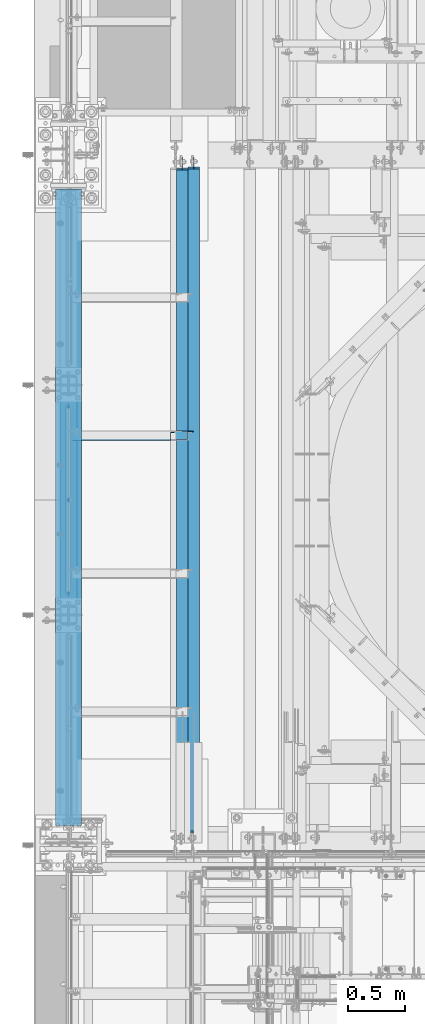
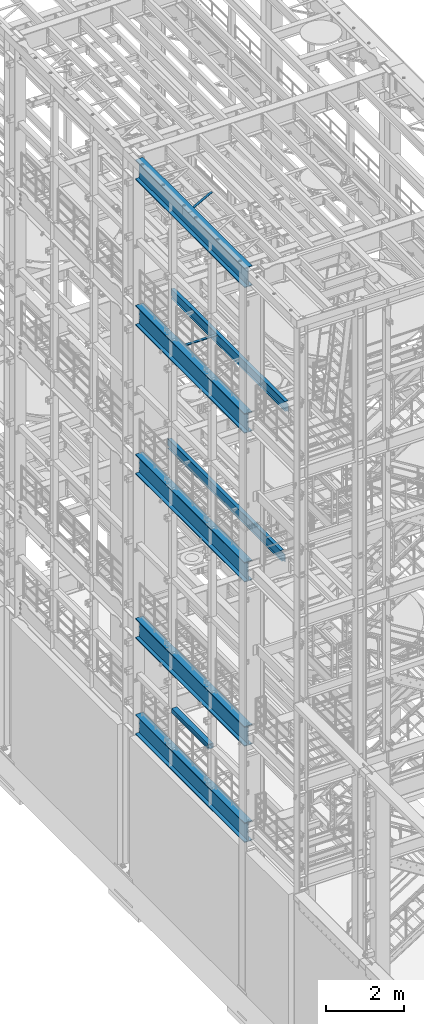
# One storey, part 1007 of 1876: 10 beams, 1 member, 11 elements without a shape of their own.
"""IFC2X3 building model written with IfcOpenShell, lengths in millimetres."""

import ifcopenshell
import ifcopenshell.guid

model = None  # the IFC model being written
_history = None  # IfcOwnerHistory: only IFC2X3 demands one
_inside = {}  # id of a spatial element -> (the spatial element, [elements in it])
_under = {}  # id of a project, library or spatial element -> (it, [spatial elements below it])
_declared = {}  # id of a project -> (the project, [libraries it declares])
_typed = {}  # id of a type object -> (the type object, [elements of that type])
_made_of = {}  # id of a material, layer set ... -> (it, [elements and type objects made of it])


def new_model(schema):
    """Start an empty IFC model of exactly this schema.

    Asked for "IFC4X3", IfcOpenShell would pick the latest addendum, in which some entities
    have other attributes; the version numbers below select the first issue.
    IFC2X3 requires an IfcOwnerHistory on every rooted entity: one is made here for all.
    """
    global model, _history
    if schema == "IFC4X3":
        model = ifcopenshell.file(schema_version=(4, 3, 0, 0))
    else:
        model = ifcopenshell.file(schema=schema)
    _inside.clear()
    _under.clear()
    _declared.clear()
    _typed.clear()
    _made_of.clear()
    _history = None
    if model.schema == "IFC2X3":
        org = make("IfcOrganization", Name="unknown")
        user = make(
            "IfcPersonAndOrganization",
            ThePerson=make("IfcPerson", FamilyName="unknown"),
            TheOrganization=org,
        )
        app = make(
            "IfcApplication",
            ApplicationDeveloper=org,
            Version="unknown",
            ApplicationFullName="unknown",
            ApplicationIdentifier="unknown",
        )
        _history = make(
            "IfcOwnerHistory",
            OwningUser=user,
            OwningApplication=app,
            ChangeAction="ADDED",
            CreationDate=0,
        )
    return model


def make(cls, **values):
    """One entity of the class cls with the attributes given. An attribute that is None is left unset."""
    return model.create_entity(
        cls, **{name: value for name, value in values.items() if value is not None}
    )


def rooted(cls, **values):
    """An entity with a GlobalId (a new one), such as an element, a storey or a relation."""
    return make(cls, GlobalId=ifcopenshell.guid.new(), OwnerHistory=_history, **values)


def si_unit(unit_type, name, prefix=None):
    """IfcSIUnit, for example si_unit("LENGTHUNIT", "METRE", prefix="MILLI")."""
    return make("IfcSIUnit", UnitType=unit_type, Prefix=prefix, Name=name)


def assignment(units):
    """IfcUnitAssignment: the units of a project."""
    return None if units is None else make("IfcUnitAssignment", Units=units)


def point(xyz):
    """IfcCartesianPoint."""
    return None if xyz is None else make("IfcCartesianPoint", Coordinates=xyz)


def direction(xyz):
    """IfcDirection."""
    return None if xyz is None else make("IfcDirection", DirectionRatios=xyz)


def frame(location, z_axis=None, x_axis=None):
    """IfcAxis2Placement3D, a coordinate frame: its origin and axes. An axis left out is left unset."""
    return make(
        "IfcAxis2Placement3D",
        Location=point(location),
        Axis=direction(z_axis),
        RefDirection=direction(x_axis),
    )


def origin_with_axes():
    """The frame at (0, 0, 0) with the z axis (0, 0, 1) and the x axis (1, 0, 0) written out."""
    return frame((0.0, 0.0, 0.0), z_axis=(0.0, 0.0, 1.0), x_axis=(1.0, 0.0, 0.0))


def place(relative_to, where):
    """IfcLocalPlacement: puts the frame where relative to a parent placement (None: the world)."""
    return make(
        "IfcLocalPlacement", PlacementRelTo=relative_to, RelativePlacement=where
    )


def context(
    kind, dimensions, precision=None, world=None, true_north=None, identifier=None
):
    """IfcGeometricRepresentationContext, for example the 3D "Model" context."""
    return make(
        "IfcGeometricRepresentationContext",
        ContextIdentifier=identifier,
        ContextType=kind,
        CoordinateSpaceDimension=dimensions,
        Precision=precision,
        WorldCoordinateSystem=world,
        TrueNorth=true_north,
    )


def subcontext(parent, identifier, kind, view, scale=None):
    """IfcGeometricRepresentationSubContext, for example "Body" below "Model"."""
    return make(
        "IfcGeometricRepresentationSubContext",
        ContextIdentifier=identifier,
        ContextType=kind,
        ParentContext=parent,
        TargetScale=scale,
        TargetView=view,
    )


def project(units=None, contexts=None):
    """IfcProject with its units and contexts."""
    return rooted(
        "IfcProject",
        Name="project",
        RepresentationContexts=contexts,
        UnitsInContext=assignment(units),
    )


def spatial(cls, under=None, at=None, **own):
    """A site, building, storey or space (cls), placed at a placement, below another one or the project."""
    s = rooted(cls, ObjectPlacement=at, **own)
    if under is not None:
        _under.setdefault(under.id(), (under, []))[1].append(s)
    return s


def faces_of(points, faces, orient=None, outer=None):
    """IfcFace entities. A face is a list of loops; a loop is a list of indices into points, from 0.

    orient and outer hold one flag for each loop. By default every Orientation is true, the
    first loop of a face is its IfcFaceOuterBound and the others are IfcFaceBound.
    """
    made = []
    for i, loops in enumerate(faces):
        bounds = []
        for j, loop in enumerate(loops):
            is_outer = j == 0 if outer is None else outer[i][j]
            bounds.append(
                make(
                    "IfcFaceOuterBound" if is_outer else "IfcFaceBound",
                    Bound=make("IfcPolyLoop", Polygon=[points[k] for k in loop]),
                    Orientation=True if orient is None else orient[i][j],
                )
            )
        made.append(make("IfcFace", Bounds=bounds))
    return made


def faceted_brep(points, faces, orient=None, outer=None, voids=None):
    """IfcFacetedBrep: a solid bounded by flat faces; with voids (closed shells), ...WithVoids."""
    shared = [point(p) for p in points]
    hull = make("IfcClosedShell", CfsFaces=faces_of(shared, faces, orient, outer))
    if voids is None:
        return make("IfcFacetedBrep", Outer=hull)
    return make(
        "IfcFacetedBrepWithVoids",
        Outer=hull,
        Voids=[
            make(cls, CfsFaces=faces_of(shared, fs, o, b)) for cls, fs, o, b in voids
        ],
    )


def shape(context_of_items, identifier, shape_type, items):
    """IfcShapeRepresentation: the items that make up one representation, for example the "Body"."""
    return make(
        "IfcShapeRepresentation",
        ContextOfItems=context_of_items,
        RepresentationIdentifier=identifier,
        RepresentationType=shape_type,
        Items=items,
    )


def material(Name=None, Category=None):
    """IfcMaterial."""
    return make("IfcMaterial", Name=Name, Category=Category)


def made_of(thing, what):
    """Note that an element or type object is made of a material, layer set ...; save() writes the relation."""
    if what is not None:
        _made_of.setdefault(what.id(), (what, []))[1].append(thing)
    return thing


def type_object(cls, material=None, **own):
    """A type object (cls), such as IfcWallType, which elements share."""
    return made_of(rooted(cls, **own), material)


def element(
    cls,
    number,
    at=None,
    inside=None,
    cuts=None,
    type_object=None,
    material=None,
    context=None,
    identifier="Body",
    shape_type=None,
    held_by="IfcProductDefinitionShape",
    body=None,
    shapes=None,
    **own,
):
    """One element of the class cls, such as IfcWall. Its Tag is "e" and its number.

    at: its placement. inside: the storey or other place that contains it. cuts: it is an
    opening in that element (IfcRelVoidsElement). A single representation is given by context,
    identifier, shape_type and body (its items); several are given by shapes. held_by: the class
    of the entity that holds the representations. save() writes the other relations.
    """
    e = rooted(cls, Tag="e%d" % number, ObjectPlacement=at, **own)
    if body is not None:
        shapes = [shape(context, identifier, shape_type, body)]
    if shapes is not None:
        e.Representation = make(held_by, Representations=shapes)
    if inside is not None:
        _inside.setdefault(inside.id(), (inside, []))[1].append(e)
    if cuts is not None:
        rooted(
            "IfcRelVoidsElement", RelatingBuildingElement=cuts, RelatedOpeningElement=e
        )
    if type_object is not None:
        _typed.setdefault(type_object.id(), (type_object, []))[1].append(e)
    return made_of(e, material)


def aggregate(whole, parts):
    """IfcRelAggregates: a whole, such as a stair, and the parts it consists of."""
    return rooted("IfcRelAggregates", RelatingObject=whole, RelatedObjects=parts)


def save(model, path):
    """Write the relations noted so far, then the file.

    IfcRelAggregates (storeys below a building ...), IfcRelContainedInSpatialStructure (elements
    in a storey), IfcRelDefinesByType, IfcRelAssociatesMaterial and IfcRelDeclares: one each for
    every whole, place, type object, material and project.
    """
    for whole, parts in _under.values():
        aggregate(whole, parts)
    for where, things in _inside.values():
        rooted(
            "IfcRelContainedInSpatialStructure",
            RelatedElements=things,
            RelatingStructure=where,
        )
    for kind, things in _typed.values():
        rooted("IfcRelDefinesByType", RelatedObjects=things, RelatingType=kind)
    for what, things in _made_of.values():
        rooted("IfcRelAssociatesMaterial", RelatedObjects=things, RelatingMaterial=what)
    for by, libraries in _declared.values():
        rooted("IfcRelDeclares", RelatingContext=by, RelatedDefinitions=libraries)
    model.write(path)


model = new_model("IFC2X3")

# Units and contexts
model_context = context("Model", 3, precision=1e-05, world=origin_with_axes())
body_context = subcontext(model_context, "Body", "Model", "MODEL_VIEW")
ifc_project = project(units=[si_unit("LENGTHUNIT", "METRE", prefix="MILLI"), si_unit("AREAUNIT", "SQUARE_METRE"), si_unit("VOLUMEUNIT", "CUBIC_METRE"), si_unit("MASSUNIT", "GRAM", prefix="KILO"), si_unit("TIMEUNIT", "SECOND"), si_unit("PLANEANGLEUNIT", "RADIAN"), si_unit("SOLIDANGLEUNIT", "STERADIAN"), si_unit("THERMODYNAMICTEMPERATUREUNIT", "DEGREE_CELSIUS"), si_unit("LUMINOUSINTENSITYUNIT", "LUMEN")], contexts=[model_context])

# Site, building, storey
site_placement = place(None, origin_with_axes())
site = spatial("IfcSite", under=ifc_project, at=site_placement, CompositionType="ELEMENT")
building_placement = place(site_placement, origin_with_axes())
building = spatial("IfcBuilding", under=site, at=building_placement, Name="Undefined", CompositionType="ELEMENT")
storey_placement = place(building_placement, origin_with_axes())
storey = spatial("IfcBuildingStorey", under=building, at=storey_placement, Name="Undefined", CompositionType="ELEMENT", Elevation=0.0)

# Assembly, beam
assembly_1_placement = place(storey_placement, origin_with_axes())
assembly_1 = element("IfcElementAssembly", 1, at=assembly_1_placement, inside=storey, Name="RAIL", AssemblyPlace="NOTDEFINED", PredefinedType="RIGID_FRAME")
ifc_material_1 = material()
beam_type_1 = type_object("IfcBeamType", Name="PIPE1-1/2SCH40", PredefinedType="NOTDEFINED")
beam_1_placement = place(assembly_1_placement, frame((-1.81898940354586e-12, -2374.9, 6207.125), z_axis=(0.0, 0.0, -1.0), x_axis=(0.0, 1.0, 0.0)))
beam_1 = element("IfcBeam", 2, at=beam_1_placement, type_object=beam_type_1, material=ifc_material_1, Name="RAIL", ObjectType="PIPE1-1/2SCH40", context=body_context, shape_type="Brep", body=[
    faceted_brep([(24.1300000000001, -20.4469999999999, 0.0), (34.3535000000002, -17.7076214311803, 10.2235000000001), (1667.4465, -17.7076214311801, 10.2235000000001), (1677.67, -20.4470000000001, 0.0), (41.8376214311802, -10.2235000000001, 17.7076214311819), (1659.96237856882, -10.2235000000001, 17.7076214311819), (44.5770000000002, 0.0, 20.4470000000001), (1657.223, 0.0, 20.4470000000001), (41.8376214311802, 10.2235000000001, 17.7076214311819), (1659.96237856882, 10.2235000000001, 17.7076214311819), (34.3535000000002, 17.7076214311803, 10.2235000000001), (1667.4465, 17.7076214311801, 10.2235000000001), (24.1300000000001, 20.4469999999999, 0.0), (1677.67, 20.4470000000001, 0.0), (13.9065000000001, 17.7076214311803, -10.2235000000001), (1687.8935, 17.7076214311801, -10.2235000000001), (6.42237856882002, 10.2235000000001, -17.7076214311819), (1695.37762143118, 10.2235000000001, -17.7076214311819), (3.68299999999999, 0.0, -20.4470000000001), (1698.117, 0.0, -20.4470000000001), (6.42237856882002, -10.2235000000001, -17.7076214311819), (1695.37762143118, -10.2235000000001, -17.7076214311819), (13.9065000000001, -17.7076214311803, -10.2235000000001), (1687.8935, -17.7076214311801, -10.2235000000001), (24.1299999999854, -24.1299999999992, 0.0), (12.0650000000064, -20.8971929933177, -12.0649999999987), (1689.735, -20.8971929933186, -12.0649999999987), (1677.67, -24.1300000000001, 0.0), (3.23280700668147, -12.0650000000001, -20.8971929933177), (1698.56719299332, -12.0649999999996, -20.8971929933177), (-1.45519152283669e-11, 0.0, -24.130000000001), (1701.8, 0.0, -24.130000000001), (3.23280700668147, 12.0650000000001, -20.8971929933177), (1698.56719299332, 12.0649999999996, -20.8971929933177), (12.0650000000064, 20.8971929933177, -12.0649999999987), (1689.735, 20.8971929933186, -12.0649999999987), (24.1300000000047, 24.1299999999992, 0.0), (1677.67, 24.1300000000001, 0.0), (36.1949999999997, 20.8971929933184, 12.0649999999987), (1665.605, 20.8971929933186, 12.0649999999987), (45.0271929933187, 12.0650000000001, 20.8971929933177), (1656.77280700668, 12.0649999999996, 20.8971929933177), (48.2600000000002, 0.0, 24.130000000001), (1653.54, 0.0, 24.130000000001), (45.0271929933187, -12.0650000000001, 20.8971929933177), (1656.77280700668, -12.0649999999996, 20.8971929933177), (36.1949999999997, -20.8971929933184, 12.0649999999987), (1665.605, -20.8971929933186, 12.0649999999987)], [[[0, 1, 2, 3]], [[1, 4, 5, 2]], [[4, 6, 7, 5]], [[6, 8, 9, 7]], [[8, 10, 11, 9]], [[10, 12, 13, 11]], [[12, 14, 15, 13]], [[14, 16, 17, 15]], [[16, 18, 19, 17]], [[18, 20, 21, 19]], [[20, 22, 23, 21]], [[22, 0, 3, 23]], [[24, 25, 26, 27]], [[25, 28, 29, 26]], [[28, 30, 31, 29]], [[30, 32, 33, 31]], [[32, 34, 35, 33]], [[34, 36, 37, 35]], [[36, 38, 39, 37]], [[38, 40, 41, 39]], [[40, 42, 43, 41]], [[42, 44, 45, 43]], [[44, 46, 47, 45]], [[46, 24, 27, 47]], [[29, 31, 33, 35, 37, 39, 41, 43, 45, 47, 27, 26], [5, 7, 9, 11, 13, 15, 17, 19, 21, 23, 3, 2]], [[46, 44, 42, 40, 38, 36, 34, 32, 30, 28, 25, 24], [22, 20, 18, 16, 14, 12, 10, 8, 6, 4, 1, 0]]]),
])
aggregate(assembly_1, [beam_1])

assembly_2_placement = place(storey_placement, origin_with_axes())
assembly_2 = element("IfcElementAssembly", 3, at=assembly_2_placement, inside=storey, Name="BEAM", AssemblyPlace="NOTDEFINED", PredefinedType="RIGID_FRAME")
ifc_material_2 = material()
beam_type_2 = type_object("IfcBeamType", Name="HSS6X6X3/8", PredefinedType="NOTDEFINED")
beam_2_placement = place(assembly_2_placement, frame((0.0, -2540.0, 6330.95), z_axis=(-1.0, 0.0, 0.0), x_axis=(0.0, 1.0, 0.0)))
beam_2 = element("IfcBeam", 4, at=beam_2_placement, type_object=beam_type_2, material=ifc_material_2, Name="BEAM", ObjectType="HSS6X6X3/8", context=body_context, shape_type="Brep", body=[
    faceted_brep([(76.2000000000007, 66.6749999999993, -66.6750000000002), (76.2000000000007, -66.6749999999993, -66.6750000000002), (1955.8, -66.6749999999993, -66.675), (1955.8, 66.6749999999993, -66.675), (76.2000000000007, -66.6749999999993, 66.6750000000002), (1955.8, -66.6749999999993, 66.675), (76.2000000000007, 66.6749999999993, 66.6750000000002), (1955.8, 66.6749999999993, 66.675), (76.2000000000007, 76.2000000000007, -76.1999999999998), (76.2000000000007, 76.2000000000007, 76.1999999999998), (1955.8, 76.2000000000007, 76.2), (1955.8, 76.2000000000007, -76.2), (76.2000000000007, -76.2000000000007, 76.1999999999998), (1955.8, -76.2000000000007, 76.2), (76.2000000000007, -76.2000000000007, -76.1999999999998), (1955.8, -76.2000000000007, -76.2)], [[[0, 1, 2, 3]], [[1, 4, 5, 2]], [[4, 6, 7, 5]], [[6, 0, 3, 7]], [[8, 9, 10, 11]], [[9, 12, 13, 10]], [[12, 14, 15, 13]], [[14, 8, 11, 15]], [[13, 15, 11, 10], [5, 7, 3, 2]], [[14, 12, 9, 8], [6, 4, 1, 0]]]),
])
aggregate(assembly_2, [beam_2])

# Assembly, member
assembly_3_placement = place(storey_placement, origin_with_axes())
assembly_3 = element("IfcElementAssembly", 5, at=assembly_3_placement, inside=storey, AssemblyPlace="NOTDEFINED", PredefinedType="RIGID_FRAME")
ifc_material_3 = material(Name="STEEL/A36")
member_type = type_object("IfcMemberType", Name="L3X3X3/8", PredefinedType="NOTDEFINED")
member_placement = place(assembly_3_placement, frame((18.2754879686868, -962.025, 22001.0692535961), z_axis=(0.0, -1.0, 0.0), x_axis=(0.877448093107104, 0.0, 0.479671600058526)))
member = element("IfcMember", 6, at=member_placement, type_object=member_type, material=ifc_material_3, ObjectType="L3X3X3/8", context=body_context, shape_type="Brep", body=[
    faceted_brep([(22.6152978728696, 38.0999999999985, -38.0999999999999), (22.6152978728696, 38.0999999999985, 38.0999999999999), (1025.78606203808, 38.1000000013628, 38.0999999999999), (1025.78606203808, 38.1000000013628, -38.0999999999999), (22.6152978728605, 28.5750000000044, 38.0999999999999), (1025.78606203807, 28.5750000013722, 38.0999999999999), (22.6152978728605, 28.5750000000044, -28.5749999999998), (1025.78606203807, 28.5750000013722, -28.5749999999998), (22.6152978728023, -38.0999999999367, -28.5749999999998), (1025.78606203801, -38.0999999985652, -28.5749999999998), (22.6152978728023, -38.0999999999367, -38.0999999999999), (1025.78606203801, -38.0999999985652, -38.0999999999999)], [[[0, 1, 2, 3]], [[1, 4, 5, 2]], [[4, 6, 7, 5]], [[6, 8, 9, 7]], [[8, 10, 11, 9]], [[10, 0, 3, 11]], [[5, 7, 9, 11, 3, 2]], [[10, 8, 6, 4, 1, 0]]]),
])
aggregate(assembly_3, [member])

# Assembly, beam
assembly_4_placement = place(storey_placement, origin_with_axes())
assembly_4 = element("IfcElementAssembly", 7, at=assembly_4_placement, inside=storey, Name="ANGLE", AssemblyPlace="NOTDEFINED", PredefinedType="RIGID_FRAME")
beam_type_3 = type_object("IfcBeamType", Name="L3X3X3/8", PredefinedType="NOTDEFINED")
beam_3_placement = place(assembly_4_placement, frame((-4.93498325010575e-08, -952.5, 17945.1), z_axis=(0.0, -1.0, 0.0), x_axis=(1.0, 0.0, 0.0)))
beam_3 = element("IfcBeam", 8, at=beam_3_placement, type_object=beam_type_3, material=ifc_material_3, Name="ANGLE", ObjectType="L3X3X3/8", context=body_context, shape_type="Brep", body=[
    faceted_brep([(115.886999817316, 28.5750000000007, 38.0999999999999), (115.886999817316, 38.0999999999985, 38.0999999999999), (115.886998826692, 38.0999999999985, -38.0999999999999), (115.88699882669, 12.699999237062, -38.0999999999999), (115.886998950515, 12.699999237062, -28.5749999999998), (115.88699895052, 28.5750000000007, -28.5749999999998), (38.8937432114558, 12.699999237062, -38.0999999999999), (38.8937433352807, 12.699999237062, -28.5749999999998), (7.14374321145577, -19.050000762938, -38.0999999999999), (7.14374333528067, -19.050000762938, -28.5749999999998), (7.1437499954859, -38.0999999999985, -38.0999999999999), (7.1437499954859, -38.0999999999985, -28.5749999999998), (1101.72500281572, 15.8750003814712, -28.5749999999998), (1089.02500300646, 28.5750000000007, -28.5749999999998), (1052.51300101518, 28.5750000000007, -28.5749999999998), (1101.72500039161, -38.0999999999985, -28.5749999999998), (1101.72500281572, 3.17500152588036, -28.5749999999998), (1052.51300281541, 28.5750000000007, 38.0999999999999), (1052.5130028154, 38.0999999999985, 38.0999999999999), (1052.513000758, 38.0999999999985, -38.0999999999999), (1052.51300075801, 28.5750001907363, -38.0999999999999), (1089.02500274928, 28.5750001907363, -38.0999999999999), (1101.72500255855, 15.8750003814712, -38.0999999999999), (1101.72500255855, 3.17500152588036, -38.0999999999999), (1101.72500039161, -38.0999999999985, -38.0999999999999)], [[[0, 1, 2, 3, 4, 5]], [[4, 3, 6, 7]], [[7, 6, 8, 9]], [[8, 10, 11, 9]], [[12, 13, 14, 5, 4, 7, 9, 11, 15, 16]], [[0, 5, 14, 17]], [[1, 0, 17, 18]], [[2, 1, 18, 19]], [[17, 14, 20, 19, 18]], [[13, 21, 20, 14]], [[12, 22, 21, 13]], [[16, 23, 22, 12]], [[10, 8, 6, 3, 2, 19, 20, 21, 22, 23, 24]], [[11, 10, 24, 15]], [[23, 16, 15, 24]]]),
])
aggregate(assembly_4, [beam_3])

assembly_5_placement = place(storey_placement, origin_with_axes())
assembly_5 = element("IfcElementAssembly", 9, at=assembly_5_placement, inside=storey, Name="BEAM", AssemblyPlace="NOTDEFINED", PredefinedType="RIGID_FRAME")
ifc_material_4 = material(Name="STEEL/A992")
beam_type_4 = type_object("IfcBeamType", Name="W12X16", PredefinedType="NOTDEFINED")
beam_4_placement = place(assembly_5_placement, frame((1104.90000034226, -4572.0, 17830.8), z_axis=(0.0, 0.0, 1.0), x_axis=(0.0, 1.0, 0.0)))
beam_4 = element("IfcBeam", 10, at=beam_4_placement, type_object=beam_type_4, material=ifc_material_4, Name="BEAM", ObjectType="W12X16", context=body_context, shape_type="Brep", body=[
    faceted_brep([(19.84375, -3.17499999999995, -126.999999999996), (19.84375, 3.17499999999995, -126.999999999996), (96.0437501907345, 3.17500002364682, -126.999999999996), (96.0437501907345, -3.17499999999995, -126.999999999996), (100.90382970878, 3.17500002380461, -127.966729922584), (100.90382970878, -3.17499999999995, -127.966729922584), (105.024006176934, 3.17500002425209, -130.719743823061), (105.024006176934, -3.17499999999995, -130.719743823061), (107.777020077412, 3.17500002492102, -134.839920291215), (107.777020077412, -3.17499999999995, -134.839920291215), (108.74375, -3.17499999999995, -139.699999809261), (108.74375, 3.17500002570978, -139.699999809261), (108.74375, 3.17500009516311, -146.049999999999), (108.74375, 50.8, -146.049999999999), (108.74375, 50.8, -152.400000000001), (108.74375, -50.8, -152.400000000001), (108.74375, -50.8, -146.049999999999), (108.74375, -3.17499999999995, -146.049999999999), (5969.79375, 50.8, 146.049999999999), (5969.79375, 3.17499999999995, 146.049999999999), (126.20625, 3.17499999999995, 146.049999999999), (126.20625, 50.8, 146.049999999999), (113.506250190735, -3.17499999999995, 107.950000000004), (113.506250190735, 3.17499998606149, 107.950000000004), (19.84375, 3.17499999999995, 107.950000000004), (19.84375, -3.17499999999995, 107.950000000004), (118.366329708781, -3.17499999999995, 108.916729922592), (118.366329708781, 3.17499998590552, 108.916729922592), (122.486506176934, -3.17499999999995, 111.669743823069), (122.486506176934, 3.17499998546009, 111.669743823069), (125.239520077413, -3.17499999999995, 115.789920291223), (125.239520077413, 3.17499998479298, 115.789920291223), (126.20625, -3.17499999999995, 120.64999980927), (126.20625, 3.17499998400558, 120.64999980927), (5969.79375, -50.8, 152.400000000001), (5969.79375, 50.8, 152.400000000001), (126.20625, 50.8, 152.400000000001), (126.20625, -50.8, 152.400000000001), (5969.79375, -50.8, 146.049999999999), (126.20625, -50.8, 146.049999999999), (5969.79375, -3.17499999999995, 146.049999999999), (126.20625, -3.17499999999995, 146.049999999999), (5969.79375, -3.17499999999995, 120.64999980927), (5969.79375, 3.17499999999995, 120.64999980927), (5970.76047992259, -3.17499999999995, 115.789920291223), (5970.76047992259, 3.17499999999995, 115.789920291223), (5973.51349382307, -3.17499999999995, 111.669743823069), (5973.51349382307, 3.17499999999995, 111.669743823069), (5977.63367029122, -3.17499999999995, 108.916729922592), (5977.63367029122, 3.17499999999995, 108.916729922592), (5982.49374980927, -3.17499999999995, 107.950000000004), (5982.49374980927, 3.17499999999995, 107.950000000004), (6076.15625, -3.17499999999995, 107.950000000004), (6076.15625, 3.17499999999995, 107.950000000004), (6076.15625, -3.17499999999995, -126.999999999996), (6076.15625, 3.17499999999995, -126.999999999996), (5999.95624980926, -3.17499999999995, -126.999999999996), (5999.95624980926, 3.17499999999995, -126.999999999996), (5995.09617029122, -3.17499999999995, -127.966729922584), (5995.09617029122, 3.17499999999995, -127.966729922584), (5990.97599382306, -3.17499999999995, -130.719743823061), (5990.97599382306, 3.17499999999995, -130.719743823061), (5988.22297992259, -3.17499999999995, -134.839920291215), (5988.22297992259, 3.17499999999995, -134.839920291215), (5987.25625, -3.17499999999995, -139.699999809261), (5987.25625, 3.17499999999995, -139.699999809261), (5987.25625, -3.17499999999995, -146.049999999999), (5987.25625, -50.8, -146.049999999999), (5987.25625, -50.8, -152.400000000001), (5987.25625, 50.8, -152.400000000001), (5987.25625, 50.8, -146.049999999999), (5987.25625, 3.17499999999995, -146.049999999999)], [[[0, 1, 2, 3]], [[3, 2, 4, 5]], [[5, 4, 6, 7]], [[7, 6, 8, 9]], [[10, 11, 12, 13, 14, 15, 16, 17]], [[9, 8, 11, 10]], [[18, 19, 20, 21]], [[22, 23, 24, 25]], [[26, 27, 23, 22]], [[28, 29, 27, 26]], [[30, 31, 29, 28]], [[32, 33, 31, 30]], [[34, 35, 36, 37]], [[38, 34, 37, 39]], [[40, 38, 39, 41]], [[37, 36, 21, 20, 33, 32, 41, 39]], [[35, 18, 21, 36]], [[34, 38, 40, 42, 43, 19, 18, 35]], [[44, 45, 43, 42]], [[46, 47, 45, 44]], [[48, 49, 47, 46]], [[50, 51, 49, 48]], [[52, 53, 51, 50]], [[53, 52, 54, 55]], [[54, 56, 57, 55]], [[58, 59, 57, 56]], [[60, 61, 59, 58]], [[62, 63, 61, 60]], [[64, 65, 63, 62]], [[66, 67, 68, 69, 70, 71, 65, 64]], [[67, 66, 17, 16]], [[68, 67, 16, 15]], [[69, 68, 15, 14]], [[70, 69, 14, 13]], [[71, 70, 13, 12]], [[6, 4, 2, 1, 24, 23, 27, 29, 31, 33, 20, 19, 43, 45, 47, 49, 51, 53, 55, 57, 59, 61, 63, 65, 71, 12, 11, 8]], [[25, 24, 1, 0]], [[66, 64, 62, 60, 58, 56, 54, 52, 50, 48, 46, 44, 42, 40, 41, 32, 30, 28, 26, 22, 25, 0, 3, 5, 7, 9, 10, 17]]]),
])
aggregate(assembly_5, [beam_4])

assembly_6_placement = place(storey_placement, origin_with_axes())
assembly_6 = element("IfcElementAssembly", 11, at=assembly_6_placement, inside=storey, Name="BEAM", AssemblyPlace="NOTDEFINED", PredefinedType="RIGID_FRAME")
beam_5_placement = place(assembly_6_placement, frame((1003.3, -4572.0, 13157.2), z_axis=(0.0, 0.0, 1.0), x_axis=(0.0, 1.0, 0.0)))
beam_5 = element("IfcBeam", 12, at=beam_5_placement, type_object=beam_type_4, material=ifc_material_4, Name="BEAM", ObjectType="W12X16", context=body_context, shape_type="Brep", body=[
    faceted_brep([(5974.55624911051, -3.17499999999995, -146.049999999999), (5974.55625, -50.8000000000001, -146.049999999999), (5974.55625, -50.8000000000001, -152.4), (5974.55625, 50.8, -152.4), (5974.55625, 50.8, -146.049999999999), (5974.55624911051, 3.17499999999995, -146.049999999999), (5974.55625, 3.17499999999995, -139.699999809265), (5974.55625, -3.17499999999995, -139.699999809265), (5975.52297992259, 3.17499999999995, -134.839920291219), (5975.52297992259, -3.17499999999995, -134.839920291219), (5978.27599382307, 3.17499999999995, -130.719743823065), (5978.27599382307, -3.17499999999995, -130.719743823065), (5982.39617029122, 3.17499999999995, -127.966729922588), (5982.39617029122, -3.17499999999995, -127.966729922588), (5987.25624980927, 3.17499999999995, -127.0), (5987.25624980927, -3.17499999999995, -127.0), (6076.15625, -3.17499999999995, -126.999999999996), (6076.15625, 3.17499999999995, -126.999999999996), (179.3875, 3.17500000000018, 146.049999999999), (179.3875, 50.8000000000002, 146.049999999999), (5961.85625, 50.8, 146.049999999999), (5961.85625, 3.17499999999995, 146.049999999999), (115.8875, -3.17500000000018, -139.699999809263), (115.8875, 3.17500000000018, -139.699999809263), (115.8875, 3.17500000000018, -146.049999999999), (115.8875, 50.8000000000002, -146.049999999999), (115.8875, 50.8000000000002, -152.4), (115.8875, -50.8000000000002, -152.4), (115.8875, -50.8000000000002, -146.049999999999), (115.8875, -3.17500000000018, -146.049999999999), (114.920770077412, -3.17500000000018, -134.839920291217), (114.920770077412, 3.17500000000018, -134.839920291217), (112.167756176934, -3.17500000000018, -130.719743823063), (112.167756176934, 3.17500000000018, -130.719743823063), (108.04757970878, -3.17500000000018, -127.966729922586), (108.04757970878, 3.17500000000018, -127.966729922586), (103.187500190735, -3.17500000000018, -126.999999999998), (103.187500190735, 3.17500000000018, -126.999999999998), (20.6374999999998, -3.17500000000018, -126.999999999998), (20.6374999999998, 3.17500000000018, -126.999999999998), (20.6374999999998, -3.17500000000018, 101.600000000002), (20.6374999999998, 3.17500000000018, 101.600000000002), (166.687500190735, -3.17500000000018, 101.600000000002), (166.687500190735, 3.17500000000018, 101.600000000002), (171.54757970878, -3.17500000000018, 102.56672992259), (171.54757970878, 3.17500000000018, 102.56672992259), (175.667756176934, -3.17500000000018, 105.319743823067), (175.667756176934, 3.17500000000018, 105.319743823067), (178.420770077412, -3.17500000000018, 109.439920291221), (178.420770077412, 3.17500000000018, 109.439920291221), (179.3875, -3.17500000000018, 114.299999809267), (179.3875, 3.17500000000018, 114.299999809267), (179.3875, -50.8000000000002, 152.4), (179.3875, 50.8000000000002, 152.4), (179.3875, -3.17500000000018, 146.049999999999), (179.3875, -50.8000000000002, 146.049999999999), (5961.85625, -3.17499999999995, 146.049999999999), (5961.85625, -50.8000000000001, 146.049999999999), (5961.85625, -50.8000000000001, 152.4), (5961.85625, 50.8, 152.4), (5961.85625, -3.17499999999995, 126.999999809264), (5961.85625, 3.17499999999995, 126.999999809264), (5962.82297992259, -3.17499999999995, 122.139920291218), (5962.82297992259, 3.17499999999995, 122.139920291218), (5965.57599382307, -3.17499999999995, 118.019743823064), (5965.57599382307, 3.17499999999995, 118.019743823064), (5969.69617029122, -3.17499999999995, 115.266729922587), (5969.69617029122, 3.17499999999995, 115.266729922587), (5974.55624980926, -3.17499999999995, 114.299999999999), (5974.55624980926, 3.17499999999995, 114.299999999999), (6076.15625, -3.17499999999995, 114.299999999999), (6076.15625, 3.17499999999995, 114.299999999999)], [[[0, 1, 2, 3, 4, 5, 6, 7]], [[7, 6, 8, 9]], [[9, 8, 10, 11]], [[11, 10, 12, 13]], [[13, 12, 14, 15]], [[16, 15, 14, 17]], [[18, 19, 20, 21]], [[22, 23, 24, 25, 26, 27, 28, 29]], [[30, 31, 23, 22]], [[32, 33, 31, 30]], [[34, 35, 33, 32]], [[36, 37, 35, 34]], [[38, 39, 37, 36]], [[40, 41, 39, 38]], [[42, 43, 41, 40]], [[44, 45, 43, 42]], [[46, 47, 45, 44]], [[48, 49, 47, 46]], [[50, 51, 49, 48]], [[52, 53, 19, 18, 51, 50, 54, 55]], [[55, 54, 56, 57]], [[52, 55, 57, 58]], [[53, 52, 58, 59]], [[19, 53, 59, 20]], [[58, 57, 56, 60, 61, 21, 20, 59]], [[62, 63, 61, 60]], [[64, 65, 63, 62]], [[66, 67, 65, 64]], [[68, 69, 67, 66]], [[70, 71, 69, 68]], [[71, 70, 16, 17]], [[12, 10, 8, 6, 5, 24, 23, 31, 33, 35, 37, 39, 41, 43, 45, 47, 49, 51, 18, 21, 61, 63, 65, 67, 69, 71, 17, 14]], [[25, 24, 5, 4]], [[26, 25, 4, 3]], [[27, 26, 3, 2]], [[28, 27, 2, 1]], [[29, 28, 1, 0]], [[70, 68, 66, 64, 62, 60, 56, 54, 50, 48, 46, 44, 42, 40, 38, 36, 34, 32, 30, 22, 29, 0, 7, 9, 11, 13, 15, 16]]]),
])
aggregate(assembly_6, [beam_5])

assembly_7_placement = place(storey_placement, origin_with_axes())
assembly_7 = element("IfcElementAssembly", 13, at=assembly_7_placement, inside=storey, Name="BEAM", AssemblyPlace="NOTDEFINED", PredefinedType="RIGID_FRAME")
beam_type_5 = type_object("IfcBeamType", Name="W24X103", PredefinedType="NOTDEFINED")
beam_6_placement = place(assembly_7_placement, frame((0.0, -4572.0, 17672.05), z_axis=(0.0, 0.0, 1.0), x_axis=(0.0, 1.0, 0.0)))
beam_6 = element("IfcBeam", 14, at=beam_6_placement, type_object=beam_type_5, material=ifc_material_4, Name="BEAM", ObjectType="W24X103", context=body_context, shape_type="Brep", body=[
    faceted_brep([(173.037499999999, -114.3, -285.75), (173.037499999999, -114.3, -311.150000000001), (5794.375, -114.3, -311.150000000001), (5794.375, -114.3, -285.75), (173.037499999999, -7.14375000000018, -285.75), (5794.375, -7.14375000000018, -285.75), (173.037499999999, -7.14375000000018, 285.75), (5794.375, -7.14375000000018, 285.75), (173.037499999999, -114.3, 285.75), (5794.375, -114.3, 285.75), (173.037499999999, -114.3, 311.150000000001), (5794.375, -114.3, 311.150000000001), (173.037499999999, 114.3, 311.150000000001), (5794.375, 114.3, 311.150000000001), (173.037499999999, 114.3, 285.75), (5794.375, 114.3, 285.75), (173.037499999999, 7.14375000000018, 285.75), (5794.375, 7.14375000000018, 285.75), (173.037499999999, 7.14375000000018, -285.75), (5794.375, 7.14375000000018, -285.75), (173.037499999999, 114.3, -285.75), (5794.375, 114.3, -285.75), (173.037499999999, 114.3, -311.150000000001), (5794.375, 114.3, -311.150000000001)], [[[0, 1, 2, 3]], [[4, 0, 3, 5]], [[6, 4, 5, 7]], [[8, 6, 7, 9]], [[10, 8, 9, 11]], [[12, 10, 11, 13]], [[14, 12, 13, 15]], [[16, 14, 15, 17]], [[18, 16, 17, 19]], [[20, 18, 19, 21]], [[1, 0, 4, 6, 8, 10, 12, 14, 16, 18, 20, 22]], [[1, 22, 23, 2]], [[19, 17, 15, 13, 11, 9, 7, 5, 3, 2, 23, 21]], [[22, 20, 21, 23]]]),
])
aggregate(assembly_7, [beam_6])

assembly_8_placement = place(storey_placement, origin_with_axes())
assembly_8 = element("IfcElementAssembly", 15, at=assembly_8_placement, inside=storey, Name="BEAM", AssemblyPlace="NOTDEFINED", PredefinedType="RIGID_FRAME")
beam_7_placement = place(assembly_8_placement, frame((0.0, -4572.0, 12998.45), z_axis=(0.0, 0.0, 1.0), x_axis=(0.0, 1.0, 0.0)))
beam_7 = element("IfcBeam", 16, at=beam_7_placement, type_object=beam_type_5, material=ifc_material_4, Name="BEAM", ObjectType="W24X103", context=body_context, shape_type="Brep", body=[
    faceted_brep([(173.037499999999, -114.3, -285.75), (173.037499999999, -114.3, -311.150000000001), (5794.375, -114.3, -311.150000000001), (5794.375, -114.3, -285.75), (173.037499999999, -7.14375000000018, -285.75), (5794.375, -7.14375000000018, -285.75), (173.037499999999, -7.14375000000018, 285.75), (5794.375, -7.14375000000018, 285.75), (173.037499999999, -114.3, 285.75), (5794.375, -114.3, 285.75), (173.037499999999, -114.3, 311.150000000001), (5794.375, -114.3, 311.150000000001), (173.037499999999, 114.3, 311.150000000001), (5794.375, 114.3, 311.150000000001), (173.037499999999, 114.3, 285.75), (5794.375, 114.3, 285.75), (173.037499999999, 7.14375000000018, 285.75), (5794.375, 7.14375000000018, 285.75), (173.037499999999, 7.14375000000018, -285.75), (5794.375, 7.14375000000018, -285.75), (173.037499999999, 114.3, -285.75), (5794.375, 114.3, -285.75), (173.037499999999, 114.3, -311.150000000001), (5794.375, 114.3, -311.150000000001)], [[[0, 1, 2, 3]], [[4, 0, 3, 5]], [[6, 4, 5, 7]], [[8, 6, 7, 9]], [[10, 8, 9, 11]], [[12, 10, 11, 13]], [[14, 12, 13, 15]], [[16, 14, 15, 17]], [[18, 16, 17, 19]], [[20, 18, 19, 21]], [[1, 0, 4, 6, 8, 10, 12, 14, 16, 18, 20, 22]], [[1, 22, 23, 2]], [[19, 17, 15, 13, 11, 9, 7, 5, 3, 2, 23, 21]], [[22, 20, 21, 23]]]),
])
aggregate(assembly_8, [beam_7])

assembly_9_placement = place(storey_placement, origin_with_axes())
assembly_9 = element("IfcElementAssembly", 17, at=assembly_9_placement, inside=storey, Name="BEAM", AssemblyPlace="NOTDEFINED", PredefinedType="RIGID_FRAME")
beam_8_placement = place(assembly_9_placement, frame((0.0, -4572.0, 7842.25), z_axis=(0.0, 0.0, 1.0), x_axis=(0.0, 1.0, 0.0)))
beam_8 = element("IfcBeam", 18, at=beam_8_placement, type_object=beam_type_5, material=ifc_material_4, Name="BEAM", ObjectType="W24X103", context=body_context, shape_type="Brep", body=[
    faceted_brep([(173.037499999999, -114.3, -285.75), (173.037499999999, -114.3, -311.150000000001), (5794.375, -114.3, -311.150000000001), (5794.375, -114.3, -285.75), (173.037499999999, -7.14375000000018, -285.75), (5794.375, -7.14375000000018, -285.75), (173.037499999999, -7.14375000000018, 285.75), (5794.375, -7.14375000000018, 285.75), (173.037499999999, -114.3, 285.75), (5794.375, -114.3, 285.75), (173.037499999999, -114.3, 311.150000000001), (5794.375, -114.3, 311.150000000001), (173.037499999999, 114.3, 311.150000000001), (5794.375, 114.3, 311.150000000001), (173.037499999999, 114.3, 285.75), (5794.375, 114.3, 285.75), (173.037499999999, 7.14375000000018, 285.75), (5794.375, 7.14375000000018, 285.75), (173.037499999999, 7.14375000000018, -285.75), (5794.375, 7.14375000000018, -285.75), (173.037499999999, 114.3, -285.75), (5794.375, 114.3, -285.75), (173.037499999999, 114.3, -311.150000000001), (5794.375, 114.3, -311.150000000001)], [[[0, 1, 2, 3]], [[4, 0, 3, 5]], [[6, 4, 5, 7]], [[8, 6, 7, 9]], [[10, 8, 9, 11]], [[12, 10, 11, 13]], [[14, 12, 13, 15]], [[16, 14, 15, 17]], [[18, 16, 17, 19]], [[20, 18, 19, 21]], [[1, 0, 4, 6, 8, 10, 12, 14, 16, 18, 20, 22]], [[1, 22, 23, 2]], [[19, 17, 15, 13, 11, 9, 7, 5, 3, 2, 23, 21]], [[22, 20, 21, 23]]]),
])
aggregate(assembly_9, [beam_8])

assembly_10_placement = place(storey_placement, origin_with_axes())
assembly_10 = element("IfcElementAssembly", 19, at=assembly_10_placement, inside=storey, Name="BEAM", AssemblyPlace="NOTDEFINED", PredefinedType="RIGID_FRAME")
beam_9_placement = place(assembly_10_placement, frame((0.0, -4572.0, 22244.05), z_axis=(0.0, 0.0, 1.0), x_axis=(0.0, 1.0, 0.0)))
beam_9 = element("IfcBeam", 20, at=beam_9_placement, type_object=beam_type_5, material=ifc_material_4, Name="BEAM", ObjectType="W24X103", context=body_context, shape_type="Brep", body=[
    faceted_brep([(173.037499999999, -114.3, -285.75), (173.037499999999, -114.3, -311.150000000001), (5794.375, -114.3, -311.150000000001), (5794.375, -114.3, -285.75), (173.037499999999, -7.14375000000018, -285.75), (5794.375, -7.14375000000018, -285.75), (173.037499999999, -7.14375000000018, 285.75), (5794.375, -7.14375000000018, 285.75), (173.037499999999, -114.3, 285.75), (5794.375, -114.3, 285.75), (173.037499999999, -114.3, 311.150000000001), (5794.375, -114.3, 311.150000000001), (173.037499999999, 114.3, 311.150000000001), (5794.375, 114.3, 311.150000000001), (173.037499999999, 114.3, 285.75), (5794.375, 114.3, 285.75), (173.037499999999, 7.14375000000018, 285.75), (5794.375, 7.14375000000018, 285.75), (173.037499999999, 7.14375000000018, -285.75), (5794.375, 7.14375000000018, -285.75), (173.037499999999, 114.3, -285.75), (5794.375, 114.3, -285.75), (173.037499999999, 114.3, -311.150000000001), (5794.375, 114.3, -311.150000000001)], [[[0, 1, 2, 3]], [[4, 0, 3, 5]], [[6, 4, 5, 7]], [[8, 6, 7, 9]], [[10, 8, 9, 11]], [[12, 10, 11, 13]], [[14, 12, 13, 15]], [[16, 14, 15, 17]], [[18, 16, 17, 19]], [[20, 18, 19, 21]], [[1, 0, 4, 6, 8, 10, 12, 14, 16, 18, 20, 22]], [[1, 22, 23, 2]], [[19, 17, 15, 13, 11, 9, 7, 5, 3, 2, 23, 21]], [[22, 20, 21, 23]]]),
])
aggregate(assembly_10, [beam_9])

assembly_11_placement = place(storey_placement, origin_with_axes())
assembly_11 = element("IfcElementAssembly", 21, at=assembly_11_placement, inside=storey, Name="BEAM", AssemblyPlace="NOTDEFINED", PredefinedType="RIGID_FRAME")
beam_10_placement = place(assembly_11_placement, frame((0.0, -4572.0, 4819.65), z_axis=(0.0, 0.0, 1.0), x_axis=(0.0, 1.0, 0.0)))
beam_10 = element("IfcBeam", 22, at=beam_10_placement, type_object=beam_type_5, material=ifc_material_4, Name="BEAM", ObjectType="W24X103", context=body_context, shape_type="Brep", body=[
    faceted_brep([(173.037499999999, -114.3, -285.75), (173.037499999999, -114.3, -311.150000000001), (5794.375, -114.3, -311.150000000001), (5794.375, -114.3, -285.75), (173.037499999999, -7.14375000000018, -285.75), (5794.375, -7.14375000000018, -285.75), (173.037499999999, -7.14375000000018, 285.75), (5794.375, -7.14375000000018, 285.75), (173.037499999999, -114.3, 285.75), (5794.375, -114.3, 285.75), (173.037499999999, -114.3, 311.150000000001), (5794.375, -114.3, 311.150000000001), (173.037499999999, 114.3, 311.150000000001), (5794.375, 114.3, 311.150000000001), (173.037499999999, 114.3, 285.75), (5794.375, 114.3, 285.75), (173.037499999999, 7.14375000000018, 285.75), (5794.375, 7.14375000000018, 285.75), (173.037499999999, 7.14375000000018, -285.75), (5794.375, 7.14375000000018, -285.75), (173.037499999999, 114.3, -285.75), (5794.375, 114.3, -285.75), (173.037499999999, 114.3, -311.150000000001), (5794.375, 114.3, -311.150000000001)], [[[0, 1, 2, 3]], [[4, 0, 3, 5]], [[6, 4, 5, 7]], [[8, 6, 7, 9]], [[10, 8, 9, 11]], [[12, 10, 11, 13]], [[14, 12, 13, 15]], [[16, 14, 15, 17]], [[18, 16, 17, 19]], [[20, 18, 19, 21]], [[1, 0, 4, 6, 8, 10, 12, 14, 16, 18, 20, 22]], [[1, 22, 23, 2]], [[19, 17, 15, 13, 11, 9, 7, 5, 3, 2, 23, 21]], [[22, 20, 21, 23]]]),
])
aggregate(assembly_11, [beam_10])

save(model, "model.ifc")
